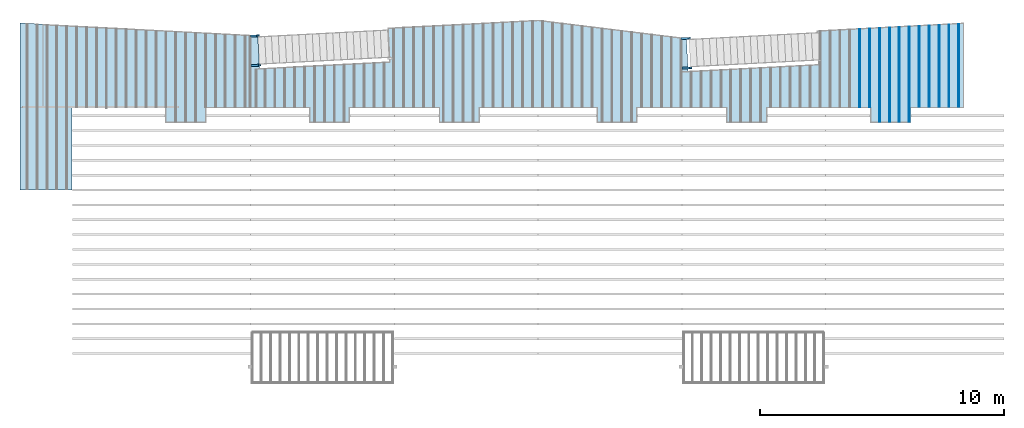
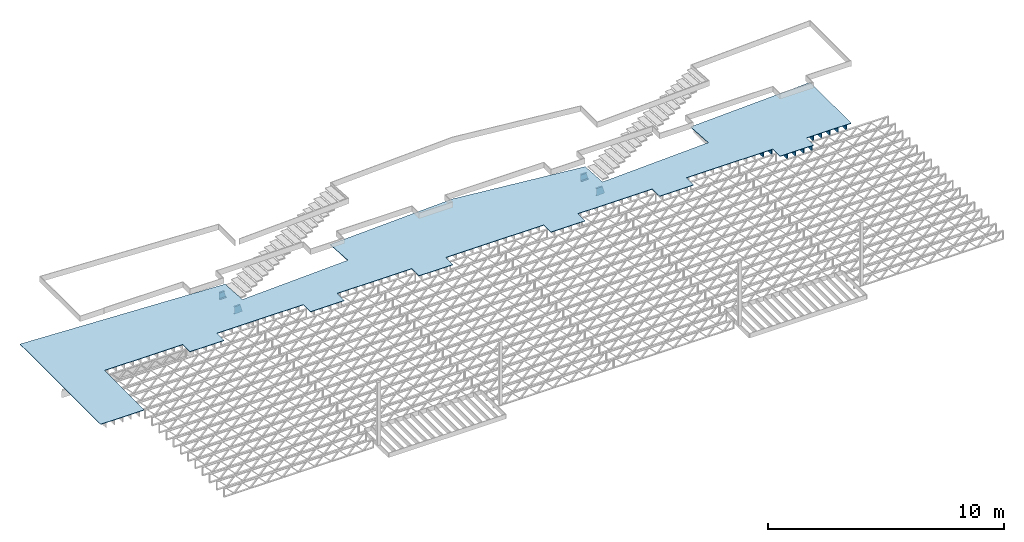
# One storey, part 12 of 23: 15 beams, 1 slab, 1 element without a shape of its own.
"""IFC4 building model written with IfcOpenShell, lengths in feet."""

from ifc_helpers import new_model, entity, si_unit, converted_unit, derived_unit, direction, frame, frame_2d, origin, origin_2d_with_axis, place, context, subcontext, project, spatial, polyline, circle_curve, parameter, trimmed, segment, composite_curve, rectangle, outline, extrude, clip, halfspace, source, transform, mapped, material, layer, layer_set, layer_usage, material_profile, profile_set, profile_usage, type_object, type_shapes, element, aggregate, save


model = new_model("IFC4")

# Units and contexts
model_context = context("Model", 3, precision=0.0001, world=origin(), true_north=direction((6.12303176911189e-17, 1.0)))
body_context = subcontext(model_context, "Body", "Model", "MODEL_VIEW")
ifc_project = project(units=[converted_unit("LENGTHUNIT", "FOOT", entity("IfcRatioMeasure", 0.3048), si_unit("LENGTHUNIT", "METRE"), dimensions=[1, 0, 0, 0, 0, 0, 0]), converted_unit("AREAUNIT", "SQUARE FOOT", entity("IfcRatioMeasure", 0.09290304), si_unit("AREAUNIT", "SQUARE_METRE"), dimensions=[2, 0, 0, 0, 0, 0, 0]), converted_unit("VOLUMEUNIT", "CUBIC FOOT", entity("IfcRatioMeasure", 0.028316846592), si_unit("VOLUMEUNIT", "CUBIC_METRE"), dimensions=[3, 0, 0, 0, 0, 0, 0]), converted_unit("PLANEANGLEUNIT", "DEGREE", entity("IfcRatioMeasure", 0.0174532925199433), si_unit("PLANEANGLEUNIT", "RADIAN"), dimensions=[0, 0, 0, 0, 0, 0, 0]), si_unit("MASSUNIT", "GRAM", prefix="KILO"), derived_unit("MASSDENSITYUNIT", [(si_unit("MASSUNIT", "GRAM", prefix="KILO"), 1), (si_unit("LENGTHUNIT", "METRE"), -3)]), derived_unit("MOMENTOFINERTIAUNIT", [(si_unit("LENGTHUNIT", "METRE"), 4)]), si_unit("TIMEUNIT", "SECOND"), si_unit("FREQUENCYUNIT", "HERTZ"), si_unit("THERMODYNAMICTEMPERATUREUNIT", "DEGREE_CELSIUS"), derived_unit("THERMALTRANSMITTANCEUNIT", [(si_unit("MASSUNIT", "GRAM", prefix="KILO"), 1), (si_unit("THERMODYNAMICTEMPERATUREUNIT", "KELVIN"), -1), (si_unit("TIMEUNIT", "SECOND"), -3)]), derived_unit("VOLUMETRICFLOWRATEUNIT", [(si_unit("LENGTHUNIT", "METRE"), 3), (si_unit("TIMEUNIT", "SECOND"), -1)]), si_unit("ELECTRICCURRENTUNIT", "AMPERE"), si_unit("ELECTRICVOLTAGEUNIT", "VOLT"), si_unit("POWERUNIT", "WATT"), si_unit("FORCEUNIT", "NEWTON"), si_unit("ILLUMINANCEUNIT", "LUX"), si_unit("LUMINOUSFLUXUNIT", "LUMEN"), si_unit("LUMINOUSINTENSITYUNIT", "CANDELA"), derived_unit("USERDEFINED", [(si_unit("MASSUNIT", "GRAM", prefix="KILO"), -1), (si_unit("LENGTHUNIT", "METRE"), -2), (si_unit("TIMEUNIT", "SECOND"), 3), (si_unit("LUMINOUSFLUXUNIT", "LUMEN"), 1)]), derived_unit("LINEARVELOCITYUNIT", [(si_unit("LENGTHUNIT", "METRE"), 1), (si_unit("TIMEUNIT", "SECOND"), -1)]), si_unit("PRESSUREUNIT", "PASCAL"), derived_unit("USERDEFINED", [(si_unit("LENGTHUNIT", "METRE"), -2), (si_unit("MASSUNIT", "GRAM", prefix="KILO"), 1), (si_unit("TIMEUNIT", "SECOND"), -2)]), derived_unit("LINEARFORCEUNIT", [(si_unit("MASSUNIT", "GRAM", prefix="KILO"), 1), (si_unit("LENGTHUNIT", "METRE"), 1), (si_unit("TIMEUNIT", "SECOND"), -2), (si_unit("LENGTHUNIT", "METRE"), -1)]), derived_unit("PLANARFORCEUNIT", [(si_unit("MASSUNIT", "GRAM", prefix="KILO"), 1), (si_unit("LENGTHUNIT", "METRE"), 1), (si_unit("TIMEUNIT", "SECOND"), -2), (si_unit("LENGTHUNIT", "METRE"), -2)])], contexts=[model_context])

# Site, building, storey
site_placement = place(None, origin())
site = spatial("IfcSite", under=ifc_project, at=site_placement, CompositionType="ELEMENT")
building_placement = place(site_placement, origin())
building = spatial("IfcBuilding", under=site, at=building_placement, CompositionType="ELEMENT")
storey_placement = place(building_placement, frame((0.0, 0.0, 10.8020833333333)))
storey = spatial("IfcBuildingStorey", under=building, at=storey_placement, Name="2ND FLOOR", CompositionType="ELEMENT", Elevation=10.8020833333333)

# Beams
ifc_material_1 = material(Name="STEEL C CHANNEL - HDG - SEE STRUCT", Category="Materials")
ifc_material_profile_1 = material_profile(ifc_material_1, outline(composite_curve([segment(polyline([(-0.625000000000096, -0.136458333333336), (0.625000000000011, -0.136458333333336)]), True, "CONTINUOUS"), segment(polyline([(0.625000000000011, -0.136458333333336), (0.625000000000011, 0.14687499999997)]), True, "CONTINUOUS"), segment(trimmed(circle_curve(frame_2d((0.624999999999954, 0.0927083333333472), x_axis=(0.0, 1.0)), 0.054166666666607), [parameter(0.0)], [parameter(90.0000000000565)], True, "PARAMETER"), True, "CONTINUOUS"), segment(polyline([(0.570833333333347, 0.0927083333333473), (0.539816380436459, -0.1031250000001)]), True, "CONTINUOUS"), segment(polyline([(0.539816380436459, -0.103124999999986), (-0.539816380436541, -0.103124999999985)]), True, "CONTINUOUS"), segment(polyline([(-0.539816380436431, -0.103124999999985), (-0.570833333333319, 0.0927083333333486)]), True, "CONTINUOUS"), segment(trimmed(circle_curve(frame_2d((-0.624999999999922, 0.0927083333333487), x_axis=(1.0, 0.0)), 0.0541666666665973), [parameter(0.0)], [parameter(90.0000000001767)], True, "PARAMETER"), True, "CONTINUOUS"), segment(polyline([(-0.624999999999989, 0.14687499999997), (-0.624999999999986, -0.136458333333336)]), True, "CONTINUOUS")], self_intersect=False)), Name="C15x33.9, TYP. STRINGER")
ifc_profile_set_1 = profile_set([ifc_material_profile_1], Name="C15x33.9, TYP. STRINGER")
ifc_profile_usage_1 = profile_usage(ifc_profile_set_1, cardinal=8)
beam_type_1 = type_object("IfcBeamType", Name="C-Channel:C15x33.9, TYP. STRINGER", PredefinedType="BEAM", material=ifc_profile_set_1)
shared_shape_1 = source(origin(), body_context, "Body", "Clipping", [
    clip(clip(extrude(outline(composite_curve([segment(polyline([(-0.625000000000227, -0.136458333333221), (0.625000000000027, -0.136458333333221)]), True, "CONTINUOUS"), segment(polyline([(0.625000000000027, -0.136458333333221), (0.625000000000027, 0.146875000000426)]), True, "CONTINUOUS"), segment(trimmed(circle_curve(frame_2d((0.624999999999968, 0.0927083333334622), x_axis=(0.0, 1.0)), 0.0541666666666086), [parameter(0.0)], [parameter(90.0000000000584)], True, "PARAMETER"), True, "CONTINUOUS"), segment(polyline([(0.570833333333399, 0.0927083333336894), (0.539816380436473, -0.103124999999871)]), True, "CONTINUOUS"), segment(polyline([(0.539816380436475, -0.103124999999871), (-0.539816380436669, -0.10312499999987)]), True, "CONTINUOUS"), segment(polyline([(-0.539816380436415, -0.10312499999987), (-0.570833333333322, 0.0927083333335772)]), True, "CONTINUOUS"), segment(trimmed(circle_curve(frame_2d((-0.62499999999992, 0.0927083333334637), x_axis=(1.0, 0.0)), 0.0541666666666016), [parameter(0.0)], [parameter(90.0000000003082)], True, "PARAMETER"), True, "CONTINUOUS"), segment(polyline([(-0.624999999999973, 0.1468750000002), (-0.624999999999973, -0.136458333333221)]), True, "CONTINUOUS")], self_intersect=False)), frame((-241.745847329124, 968.572287142718, 8.97916666667323), z_axis=(0.998629534754581, 0.0523359562428164, 0.0), x_axis=(0.0, 0.0, 1.0)), (0.0, 0.0, 1.0), 1.16784078307327), halfspace(frame((-241.738160485591, 933.741866098016, 4.0), z_axis=(-1.0, 0.0, 0.0), x_axis=(0.0, -1.0, 0.0)), False)), halfspace(frame((-240.034458951307, 965.538675935652, 6.99303841413297), z_axis=(0.961401963826961, 0.0503849419223695, 0.270495141503766), x_axis=(0.270124437313279, 0.0141566218896707, -0.962721339964404)), False)),
])
type_shapes(beam_type_1, [shared_shape_1])
beam_1_placement = place(storey_placement, frame((0.0, 0.0, -10.8020833333333)))
element("IfcBeam", 1, at=beam_1_placement, inside=storey, type_object=beam_type_1, material=ifc_profile_usage_1, Name="C-Channel:C15x33.9, TYP. STRINGER", ObjectType="C-Channel:C15x33.9, TYP. STRINGER", PredefinedType="BEAM", context=body_context, shape_type="MappedRepresentation", body=[
    mapped(shared_shape_1, transform((0.0, 0.0, 0.0), scale=1.0)),
])
ifc_profile_usage_2 = profile_usage(ifc_profile_set_1, cardinal=8)
beam_type_2 = type_object("IfcBeamType", Name="C-Channel:C15x33.9, TYP. STRINGER", PredefinedType="BEAM", material=ifc_profile_set_1)
shared_shape_2 = source(origin(), body_context, "Body", "Clipping", [
    clip(extrude(outline(composite_curve([segment(polyline([(-0.146875000000084, -0.624999999999993), (0.136458333333448, -0.624999999999993)]), True, "CONTINUOUS"), segment(polyline([(0.13645833333322, -0.625000000000076), (0.136458333333333, 0.625000000000007)]), True, "CONTINUOUS"), segment(polyline([(0.136458333333448, 0.625000000000007), (-0.146874999999971, 0.625000000000007)]), True, "CONTINUOUS"), segment(trimmed(circle_curve(frame_2d((-0.0927083333334615, 0.624999999999929), x_axis=(-1.0, 0.0)), 0.0541666666665845), [parameter(0.0)], [parameter(90.0000000002029)], True, "PARAMETER"), True, "CONTINUOUS"), segment(polyline([(-0.0927083333334615, 0.570833333333338), (0.103124999999984, 0.539816380436438)]), True, "CONTINUOUS"), segment(polyline([(0.10312499999987, 0.539816380436449), (0.10312499999987, -0.539816380436518)]), True, "CONTINUOUS"), segment(polyline([(0.103125000000098, -0.539816380436406), (-0.0927083333334615, -0.570833333333331)]), True, "CONTINUOUS"), segment(trimmed(circle_curve(frame_2d((-0.092708333333575, -0.62499999999987), x_axis=(0.0, 1.0)), 0.0541666666665441), [parameter(0.0)], [parameter(90.0000000005389)], True, "PARAMETER"), True, "CONTINUOUS")], self_intersect=False)), frame((-241.721090693233, 964.591043315299, 8.97916666666633), z_axis=(0.99862953475458, 0.0523359562428374, 0.0), x_axis=(0.0523359562428374, -0.99862953475458, 0.0)), (0.0, 0.0, 1.0), 1.35148027803678), halfspace(frame((-240.034458951307, 965.538675935652, 6.99303841413297), z_axis=(0.961401963826961, 0.0503849419223695, 0.270495141503766), x_axis=(0.270124437313279, 0.0141566218896707, -0.962721339964404)), False)),
])
type_shapes(beam_type_2, [shared_shape_2])
beam_2_placement = place(storey_placement, frame((0.0, 0.0, -10.8020833333333)))
element("IfcBeam", 2, at=beam_2_placement, inside=storey, type_object=beam_type_2, material=ifc_profile_usage_2, Name="C-Channel:C15x33.9, TYP. STRINGER", ObjectType="C-Channel:C15x33.9, TYP. STRINGER", PredefinedType="BEAM", context=body_context, shape_type="MappedRepresentation", body=[
    mapped(shared_shape_2, transform((0.0, 0.0, 0.0), scale=1.0)),
])

# Assembly, beams
assembly_placement = place(storey_placement, origin())
assembly = element("IfcElementAssembly", 3, at=assembly_placement, inside=storey, Name="Structural Beam System:Structural Framing System", ObjectType="Structural Beam System:Structural Framing System", AssemblyPlace="NOTDEFINED", PredefinedType="BEAM_GRID")
ifc_material_2 = material(Category="Materials")
ifc_material_profile_2 = material_profile(ifc_material_2, rectangle(XDim=0.9375, YDim=0.125000000000011, at=origin_2d_with_axis()))
ifc_profile_set_2 = profile_set([ifc_material_profile_2])
ifc_profile_usage_3 = profile_usage(ifc_profile_set_2, cardinal=8)
beam_type_3 = type_object("IfcBeamType", PredefinedType="BEAM", material=ifc_profile_set_2)
shared_shape_3 = source(origin(), body_context, "Body", "SweptSolid", [
    extrude(rectangle(XDim=0.9375, YDim=0.125000000000011, at=origin_2d_with_axis()), frame((-5.23133528385324, 0.0, 0.0), z_axis=(1.0, 0.0, 0.0), x_axis=(0.0, 0.0, -1.0)), (0.0, 0.0, 1.0), 10.4626705677065),
])
type_shapes(beam_type_3, [shared_shape_3])
beam_3_placement = place(assembly_placement, frame((-159.800660485462, 964.259939272139, -0.729166666666744), z_axis=(0.0, 0.0, 1.0), x_axis=(0.0, 1.0, 0.0)))
beam_3 = element("IfcBeam", 4, at=beam_3_placement, type_object=beam_type_3, material=ifc_profile_usage_3, PredefinedType="BEAM", context=body_context, shape_type="MappedRepresentation", body=[
    mapped(shared_shape_3, transform((0.0, 0.0, 0.0), scale=1.0)),
])
ifc_profile_usage_4 = profile_usage(ifc_profile_set_2, cardinal=8)
beam_type_4 = type_object("IfcBeamType", PredefinedType="BEAM", material=ifc_profile_set_2)
shared_shape_4 = source(origin(), body_context, "Body", "SweptSolid", [
    extrude(rectangle(XDim=0.9375, YDim=0.125000000000011, at=origin_2d_with_axis()), frame((-5.26627363587414, 0.0, 0.0), z_axis=(1.0, 0.0, 0.0), x_axis=(0.0, 0.0, -1.0)), (0.0, 0.0, 1.0), 10.5325472717483),
])
type_shapes(beam_type_4, [shared_shape_4])
beam_4_placement = place(assembly_placement, frame((-158.467327152129, 964.294877959162, -0.729166666666744), z_axis=(0.0, 0.0, 1.0), x_axis=(0.0, 1.0, 0.0)))
beam_4 = element("IfcBeam", 5, at=beam_4_placement, type_object=beam_type_4, material=ifc_profile_usage_4, PredefinedType="BEAM", context=body_context, shape_type="MappedRepresentation", body=[
    mapped(shared_shape_4, transform((0.0, 0.0, 0.0), scale=1.0)),
])
ifc_profile_usage_5 = profile_usage(ifc_profile_set_2, cardinal=8)
beam_type_5 = type_object("IfcBeamType", PredefinedType="BEAM", material=ifc_profile_set_2)
shared_shape_5 = source(origin(), body_context, "Body", "SweptSolid", [
    extrude(rectangle(XDim=0.9375, YDim=0.125000000000011, at=origin_2d_with_axis()), frame((-6.30121354238122, 0.0, 0.0), z_axis=(1.0, 0.0, 0.0), x_axis=(0.0, 0.0, -1.0)), (0.0, 0.0, 1.0), 12.6024270847624),
])
type_shapes(beam_type_5, [shared_shape_5])
beam_5_placement = place(assembly_placement, frame((-157.133993818795, 963.329815091699, -0.729166666666744), z_axis=(0.0, 0.0, 1.0), x_axis=(0.0, 1.0, 0.0)))
beam_5 = element("IfcBeam", 6, at=beam_5_placement, type_object=beam_type_5, material=ifc_profile_usage_5, PredefinedType="BEAM", context=body_context, shape_type="MappedRepresentation", body=[
    mapped(shared_shape_5, transform((0.0, 0.0, 0.0), scale=1.0)),
])
ifc_profile_usage_6 = profile_usage(ifc_profile_set_2, cardinal=8)
beam_type_6 = type_object("IfcBeamType", PredefinedType="BEAM", material=ifc_profile_set_2)
shared_shape_6 = source(origin(), body_context, "Body", "SweptSolid", [
    extrude(rectangle(XDim=0.9375, YDim=0.125000000000011, at=origin_2d_with_axis()), frame((-6.33615206190325, 0.0, 0.0), z_axis=(1.0, 0.0, 0.0), x_axis=(0.0, 0.0, -1.0)), (0.0, 0.0, 1.0), 12.6723041238065),
])
type_shapes(beam_type_6, [shared_shape_6])
beam_6_placement = place(assembly_placement, frame((-155.800660485462, 963.364753611221, -0.729166666666744), z_axis=(0.0, 0.0, 1.0), x_axis=(0.0, 1.0, 0.0)))
beam_6 = element("IfcBeam", 7, at=beam_6_placement, type_object=beam_type_6, material=ifc_profile_usage_6, PredefinedType="BEAM", context=body_context, shape_type="MappedRepresentation", body=[
    mapped(shared_shape_6, transform((0.0, 0.0, 0.0), scale=1.0)),
])
ifc_profile_usage_7 = profile_usage(ifc_profile_set_2, cardinal=8)
beam_type_7 = type_object("IfcBeamType", PredefinedType="BEAM", material=ifc_profile_set_2)
shared_shape_7 = source(origin(), body_context, "Body", "SweptSolid", [
    extrude(rectangle(XDim=0.9375, YDim=0.125000000000011, at=origin_2d_with_axis()), frame((-6.37109058142528, 0.0, 0.0), z_axis=(1.0, 0.0, 0.0), x_axis=(0.0, 0.0, -1.0)), (0.0, 0.0, 1.0), 12.7421811628506),
])
type_shapes(beam_type_7, [shared_shape_7])
beam_7_placement = place(assembly_placement, frame((-154.467327152129, 963.399692130743, -0.729166666666744), z_axis=(0.0, 0.0, 1.0), x_axis=(0.0, 1.0, 0.0)))
beam_7 = element("IfcBeam", 8, at=beam_7_placement, type_object=beam_type_7, material=ifc_profile_usage_7, PredefinedType="BEAM", context=body_context, shape_type="MappedRepresentation", body=[
    mapped(shared_shape_7, transform((0.0, 0.0, 0.0), scale=1.0)),
])
ifc_profile_usage_8 = profile_usage(ifc_profile_set_2, cardinal=8)
beam_type_8 = type_object("IfcBeamType", PredefinedType="BEAM", material=ifc_profile_set_2)
shared_shape_8 = source(origin(), body_context, "Body", "SweptSolid", [
    extrude(rectangle(XDim=0.9375, YDim=0.125000000000011, at=origin_2d_with_axis()), frame((-6.40602910094731, 0.0, 0.0), z_axis=(1.0, 0.0, 0.0), x_axis=(0.0, 0.0, -1.0)), (0.0, 0.0, 1.0), 12.8120582018946),
])
type_shapes(beam_type_8, [shared_shape_8])
beam_8_placement = place(assembly_placement, frame((-153.133993818795, 963.434630650265, -0.729166666666744), z_axis=(0.0, 0.0, 1.0), x_axis=(0.0, 1.0, 0.0)))
beam_8 = element("IfcBeam", 9, at=beam_8_placement, type_object=beam_type_8, material=ifc_profile_usage_8, PredefinedType="BEAM", context=body_context, shape_type="MappedRepresentation", body=[
    mapped(shared_shape_8, transform((0.0, 0.0, 0.0), scale=1.0)),
])
ifc_profile_usage_9 = profile_usage(ifc_profile_set_2, cardinal=8)
beam_type_9 = type_object("IfcBeamType", PredefinedType="BEAM", material=ifc_profile_set_2)
shared_shape_9 = source(origin(), body_context, "Body", "SweptSolid", [
    extrude(rectangle(XDim=0.9375, YDim=0.125000000000011, at=origin_2d_with_axis()), frame((-5.43575938370998, 0.0, 0.0), z_axis=(1.0, 0.0, 0.0), x_axis=(0.0, 0.0, -1.0)), (0.0, 0.0, 1.0), 10.87151876742),
])
type_shapes(beam_type_9, [shared_shape_9])
beam_9_placement = place(assembly_placement, frame((-151.800660485462, 964.474777406546, -0.729166666666744), z_axis=(0.0, 0.0, 1.0), x_axis=(0.0, 1.0, 0.0)))
beam_9 = element("IfcBeam", 10, at=beam_9_placement, type_object=beam_type_9, material=ifc_profile_usage_9, PredefinedType="BEAM", context=body_context, shape_type="MappedRepresentation", body=[
    mapped(shared_shape_9, transform((0.0, 0.0, 0.0), scale=1.0)),
])
ifc_profile_usage_10 = profile_usage(ifc_profile_set_2, cardinal=8)
beam_type_10 = type_object("IfcBeamType", PredefinedType="BEAM", material=ifc_profile_set_2)
shared_shape_10 = source(origin(), body_context, "Body", "SweptSolid", [
    extrude(rectangle(XDim=0.9375, YDim=0.125000000000011, at=origin_2d_with_axis()), frame((-5.47069773573082, 0.0, 0.0), z_axis=(1.0, 0.0, 0.0), x_axis=(0.0, 0.0, -1.0)), (0.0, 0.0, 1.0), 10.9413954714616),
])
type_shapes(beam_type_10, [shared_shape_10])
beam_10_placement = place(assembly_placement, frame((-150.467327152129, 964.50971609357, -0.729166666666744), z_axis=(0.0, 0.0, 1.0), x_axis=(0.0, 1.0, 0.0)))
beam_10 = element("IfcBeam", 11, at=beam_10_placement, type_object=beam_type_10, material=ifc_profile_usage_10, PredefinedType="BEAM", context=body_context, shape_type="MappedRepresentation", body=[
    mapped(shared_shape_10, transform((0.0, 0.0, 0.0), scale=1.0)),
])
ifc_profile_usage_11 = profile_usage(ifc_profile_set_2, cardinal=8)
beam_type_11 = type_object("IfcBeamType", PredefinedType="BEAM", material=ifc_profile_set_2)
shared_shape_11 = source(origin(), body_context, "Body", "SweptSolid", [
    extrude(rectangle(XDim=0.9375, YDim=0.125000000000011, at=origin_2d_with_axis()), frame((-5.50563608775167, 0.0, 0.0), z_axis=(1.0, 0.0, 0.0), x_axis=(0.0, 0.0, -1.0)), (0.0, 0.0, 1.0), 11.0112721755033),
])
type_shapes(beam_type_11, [shared_shape_11])
beam_11_placement = place(assembly_placement, frame((-149.133993818795, 964.544654780593, -0.729166666666744), z_axis=(0.0, 0.0, 1.0), x_axis=(0.0, 1.0, 0.0)))
beam_11 = element("IfcBeam", 12, at=beam_11_placement, type_object=beam_type_11, material=ifc_profile_usage_11, PredefinedType="BEAM", context=body_context, shape_type="MappedRepresentation", body=[
    mapped(shared_shape_11, transform((0.0, 0.0, 0.0), scale=1.0)),
])
ifc_profile_usage_12 = profile_usage(ifc_profile_set_2, cardinal=8)
beam_type_12 = type_object("IfcBeamType", PredefinedType="BEAM", material=ifc_profile_set_2)
shared_shape_12 = source(origin(), body_context, "Body", "SweptSolid", [
    extrude(rectangle(XDim=0.9375, YDim=0.125000000000011, at=origin_2d_with_axis()), frame((-5.54057443977251, 0.0, 0.0), z_axis=(1.0, 0.0, 0.0), x_axis=(0.0, 0.0, -1.0)), (0.0, 0.0, 1.0), 11.081148879545),
])
type_shapes(beam_type_12, [shared_shape_12])
beam_12_placement = place(assembly_placement, frame((-147.800660485462, 964.579593467616, -0.729166666666744), z_axis=(0.0, 0.0, 1.0), x_axis=(0.0, 1.0, 0.0)))
beam_12 = element("IfcBeam", 13, at=beam_12_placement, type_object=beam_type_12, material=ifc_profile_usage_12, PredefinedType="BEAM", context=body_context, shape_type="MappedRepresentation", body=[
    mapped(shared_shape_12, transform((0.0, 0.0, 0.0), scale=1.0)),
])
ifc_profile_usage_13 = profile_usage(ifc_profile_set_2, cardinal=8)
beam_type_13 = type_object("IfcBeamType", PredefinedType="BEAM", material=ifc_profile_set_2)
shared_shape_13 = source(origin(), body_context, "Body", "SweptSolid", [
    extrude(rectangle(XDim=0.9375, YDim=0.125000000000011, at=origin_2d_with_axis()), frame((-5.57551279179336, 0.0, 0.0), z_axis=(1.0, 0.0, 0.0), x_axis=(0.0, 0.0, -1.0)), (0.0, 0.0, 1.0), 11.1510255835867),
])
type_shapes(beam_type_13, [shared_shape_13])
beam_13_placement = place(assembly_placement, frame((-146.467327152129, 964.614532154639, -0.729166666666744), z_axis=(0.0, 0.0, 1.0), x_axis=(0.0, 1.0, 0.0)))
beam_13 = element("IfcBeam", 14, at=beam_13_placement, type_object=beam_type_13, material=ifc_profile_usage_13, PredefinedType="BEAM", context=body_context, shape_type="MappedRepresentation", body=[
    mapped(shared_shape_13, transform((0.0, 0.0, 0.0), scale=1.0)),
])
aggregate(assembly, [beam_3, beam_4, beam_5, beam_6, beam_7, beam_8, beam_9, beam_10, beam_11, beam_12, beam_13])

# Beams
ifc_profile_usage_14 = profile_usage(ifc_profile_set_1, cardinal=8)
beam_type_14 = type_object("IfcBeamType", Name="C-Channel:C15x33.9, TYP. STRINGER", PredefinedType="BEAM", material=ifc_profile_set_1)
shared_shape_14 = source(origin(), body_context, "Body", "Clipping", [
    clip(extrude(outline(composite_curve([segment(polyline([(-0.625000000000226, -0.13645833333345), (0.625000000000028, -0.13645833333345)]), True, "CONTINUOUS"), segment(polyline([(0.625000000000028, -0.13645833333345), (0.625000000000028, 0.146875000000198)]), True, "CONTINUOUS"), segment(trimmed(circle_curve(frame_2d((0.62499999999997, 0.0927083333332329), x_axis=(0.0, 1.0)), 0.054166666666608), [parameter(0.0)], [parameter(90.0000000000584)], True, "PARAMETER"), True, "CONTINUOUS"), segment(polyline([(0.5708333333334, 0.0927083333334615), (0.539816380436475, -0.103125000000099)]), True, "CONTINUOUS"), segment(polyline([(0.539816380436477, -0.103125000000099), (-0.539816380436667, -0.103125000000101)]), True, "CONTINUOUS"), segment(polyline([(-0.539816380436413, -0.103125000000101), (-0.57083333333332, 0.0927083333333465)]), True, "CONTINUOUS"), segment(trimmed(circle_curve(frame_2d((-0.624999999999917, 0.0927083333332329), x_axis=(1.0, 0.0)), 0.0541666666665999), [parameter(0.0)], [parameter(90.0000000003101)], True, "PARAMETER"), True, "CONTINUOUS"), segment(polyline([(-0.624999999999972, 0.146874999999969), (-0.624999999999972, -0.13645833333345)]), True, "CONTINUOUS")], self_intersect=False)), frame((-183.827402830635, 968.220612288151, 8.97916666667324), z_axis=(0.998629534754575, 0.0523359562429165, 0.0), x_axis=(0.0, 0.0, 1.0)), (0.0, 0.0, 1.0), 1.24950820695101), halfspace(frame((-182.034458951307, 965.191275223808, 6.99303841413298), z_axis=(0.961401963826961, 0.0503849419223695, 0.270495141503766), x_axis=(0.270124437313279, 0.0141566218896707, -0.962721339964404)), False)),
])
type_shapes(beam_type_14, [shared_shape_14])
beam_14_placement = place(storey_placement, frame((0.0, 0.0, -10.8020833333333)))
element("IfcBeam", 15, at=beam_14_placement, inside=storey, type_object=beam_type_14, material=ifc_profile_usage_14, Name="C-Channel:C15x33.9, TYP. STRINGER", ObjectType="C-Channel:C15x33.9, TYP. STRINGER", PredefinedType="BEAM", context=body_context, shape_type="MappedRepresentation", body=[
    mapped(shared_shape_14, transform((0.0, 0.0, 0.0), scale=1.0)),
])
ifc_profile_usage_15 = profile_usage(ifc_profile_set_1, cardinal=8)
beam_type_15 = type_object("IfcBeamType", Name="C-Channel:C15x33.9, TYP. STRINGER", PredefinedType="BEAM", material=ifc_profile_set_1)
shared_shape_15 = source(origin(), body_context, "Body", "Clipping", [
    clip(extrude(outline(composite_curve([segment(polyline([(-0.146875000000083, -0.624999999999993), (0.13645833333345, -0.624999999999993)]), True, "CONTINUOUS"), segment(polyline([(0.136458333333221, -0.625000000000069), (0.136458333333221, 0.625000000000007)]), True, "CONTINUOUS"), segment(polyline([(0.13645833333345, 0.625000000000007), (-0.146875000000083, 0.625000000000007)]), True, "CONTINUOUS"), segment(trimmed(circle_curve(frame_2d((-0.09270833333346, 0.624999999999929), x_axis=(-1.0, 0.0)), 0.0541666666665845), [parameter(0.0)], [parameter(90.0000000002029)], True, "PARAMETER"), True, "CONTINUOUS"), segment(polyline([(-0.09270833333346, 0.570833333333338), (0.103125000000099, 0.539816380436422)]), True, "CONTINUOUS"), segment(polyline([(0.103124999999872, 0.539816380436449), (0.103124999999872, -0.539816380436518)]), True, "CONTINUOUS"), segment(polyline([(0.103125000000099, -0.539816380436406), (-0.09270833333346, -0.570833333333329)]), True, "CONTINUOUS"), segment(trimmed(circle_curve(frame_2d((-0.0927083333335735, -0.62499999999987), x_axis=(0.0, 1.0)), 0.0541666666665439), [parameter(0.0)], [parameter(90.0000000005408)], True, "PARAMETER"), True, "CONTINUOUS")], self_intersect=False)), frame((-183.721090693233, 964.243642603455, 8.97916666665938), z_axis=(0.99862953475458, 0.0523359562428374, 0.0), x_axis=(0.0523359562428374, -0.99862953475458, 0.0)), (0.0, 0.0, 1.0), 1.35148027803877), halfspace(frame((-182.034458951307, 965.191275223808, 6.99303841413298), z_axis=(0.961401963826961, 0.0503849419223695, 0.270495141503766), x_axis=(0.270124437313279, 0.0141566218896707, -0.962721339964404)), False)),
])
type_shapes(beam_type_15, [shared_shape_15])
beam_15_placement = place(storey_placement, frame((0.0, 0.0, -10.8020833333333)))
element("IfcBeam", 16, at=beam_15_placement, inside=storey, type_object=beam_type_15, material=ifc_profile_usage_15, Name="C-Channel:C15x33.9, TYP. STRINGER", ObjectType="C-Channel:C15x33.9, TYP. STRINGER", PredefinedType="BEAM", context=body_context, shape_type="MappedRepresentation", body=[
    mapped(shared_shape_15, transform((0.0, 0.0, 0.0), scale=1.0)),
])

# Slab
ifc_material_3 = material(Name="COMPOSITE DECKING", Category="Materials")
ifc_layer = layer(ifc_material_3, 0.0833333333333333, Name="COMPOSITE DECKING", Category="Materials")
ifc_layer_set = layer_set([ifc_layer], Name="Floor:floor")
ifc_layer_usage = layer_usage(ifc_layer_set, "AXIS3", "POSITIVE", 0.0)
slab_type = type_object("IfcSlabType", Name="Floor:floor", PredefinedType="FLOOR", material=ifc_layer_set)
slab_placement = place(storey_placement, origin())
element("IfcSlab", 17, at=slab_placement, inside=storey, type_object=slab_type, material=ifc_layer_usage, Name="Floor:floor", ObjectType="Floor:floor", PredefinedType="FLOOR", context=body_context, shape_type="SweptSolid", body=[
    extrude(outline(polyline([(-12.3582820269273, -65.8429906871204), (10.1145888440207, -65.8429906871204), (8.43819556529411, -33.8555013933543), (4.00340490843701, -33.6230838634432), (4.91877599891848, -16.1567629659345), (9.45421852244135, -16.394455436658), (10.5155528171952, 3.85700931292644), (8.0662864339871, 23.8046832321653), (3.63817692845862, 24.0367506177719), (4.55623682755117, 41.5543770399257), (9.09167929991963, 41.3166845718827), (10.1305931968635, 61.1403426462533), (-1.30619737609095, 61.1403426462533), (-1.30619917463468, 53.982009284716), (-3.31661536026036, 53.982009284716), (-3.31661536026036, 48.5236759513827), (-1.31661257058704, 48.5236759513827), (-1.31661605539693, 34.6538823976193), (-3.31661536026036, 34.6538829001229), (-3.31661536026036, 29.1903421243623), (-1.31661479650597, 29.1903425871669), (-1.31661201967938, 17.1903429668514), (-3.31661536026058, 17.1903429668514), (-3.31661536026058, 11.7268024224931), (-1.31661210079824, 11.7268029249977), (-1.31661605539693, -4.01278429915214), (-3.31661536026047, -4.01278379664859), (-3.31661536026047, -9.47632457240917), (-1.31661479650597, -9.47632410960463), (-1.31661201967995, -21.4763214849587), (-3.31661536026058, -21.4763214849587), (-3.31661536026058, -26.9398642441736), (-1.31661273991233, -26.9398637416692), (-1.31661273991233, -40.8096562762393), (-3.31661536026058, -40.8096562762393), (-3.31661536026058, -46.2679906870777), (-1.31661584130131, -46.2679906870777), (-1.31661267971845, -58.851316302527), (-12.3582820269273, -58.8513188334747), (-12.3582820269273, -65.8429906871204)])), frame((-206.928503131784, 960.220216909578, -0.177083333333204), z_axis=(0.0, 0.0, -1.0), x_axis=(0.0, 1.0, 0.0)), (0.0, 0.0, 1.0), 0.0833333333333339),
])

save(model, "model.ifc")
